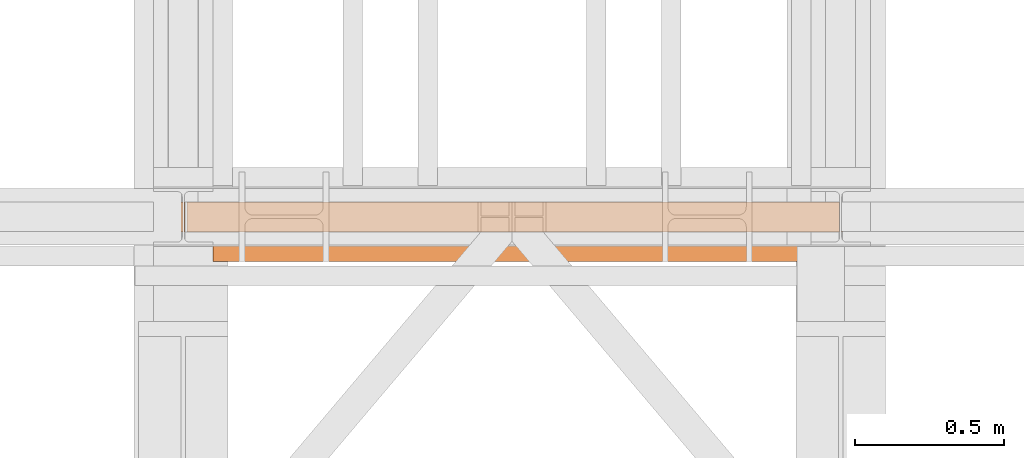
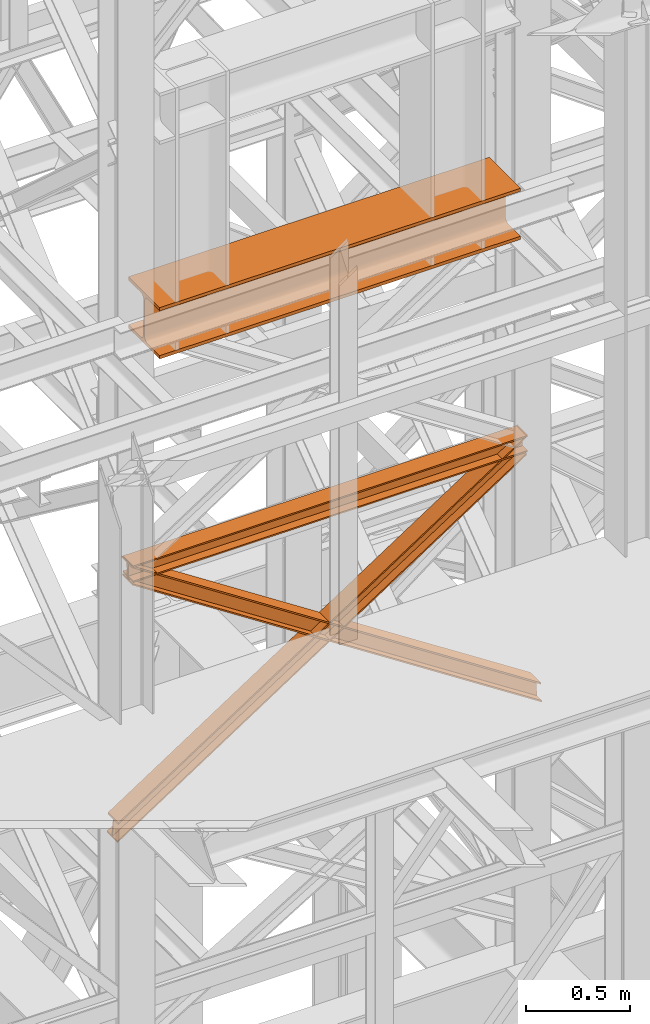
# One storey, part 147 of 208: 4 proxies.
"""IFC2X3 building model written with IfcOpenShell, lengths in millimetres."""

from ifc_helpers import new_model, entity, si_unit, converted_unit, frame, origin, origin_with_axes, place, context, subcontext, project, spatial, faceted_brep, element, save


model = new_model("IFC2X3")

# Units and contexts
model_context = context("Model", 3, precision=1e-05, world=origin())
plan_context = context("Plan", 3, precision=1e-05, world=origin())
body_context = subcontext(model_context, "Body", "Model", "MODEL_VIEW")
ifc_project = project(units=[si_unit("LENGTHUNIT", "METRE", prefix="MILLI"), converted_unit("PLANEANGLEUNIT", "DEGREE", entity("IfcPlaneAngleMeasure", 0.0174532925199433), si_unit("PLANEANGLEUNIT", "RADIAN"), dimensions=[0, 0, 0, 0, 0, 0, 0]), si_unit("AREAUNIT", "SQUARE_METRE"), si_unit("VOLUMEUNIT", "CUBIC_METRE")], contexts=[model_context, plan_context])

# Building, storey
building_placement = place(None, origin())
building = spatial("IfcBuilding", under=ifc_project, at=building_placement, CompositionType="COMPLEX")
storey_placement = place(building_placement, origin_with_axes())
storey = spatial("IfcBuildingStorey", under=building, at=storey_placement, Name="Geschoss", CompositionType="ELEMENT")

# Proxies
proxy_1_placement = place(storey_placement, frame((3393.254970018782, -16112.48734116498, 9568.990058693806), z_axis=(0.0, 0.0, 1.0), x_axis=(1.0, 0.0, 0.0)))
element("IfcBuildingElementProxy", 1, at=proxy_1_placement, inside=storey, context=body_context, shape_type="Brep", body=[
    faceted_brep([(0.01000000000021828, 300.0100000000002, 0.01000000000021828), (2000.009997019768, 300.0100000000002, 0.01000000000021828), (2000.009997019768, 300.0100000000002, 19.01000000000022), (0.01000000000021828, 300.0100000000002, 19.01000000000022), (0.01000000000021828, 300.0100000000002, 19.01000000000022), (2000.009997019768, 300.0100000000002, 19.01000000000022), (2000.009997019768, 182.5100000000002, 19.01000000000022), (0.01000000000021828, 182.5100000000002, 19.01000000000022), (0.01000000000021828, 182.5100000000002, 19.01000000000022), (2000.009997019768, 182.5100000000002, 19.01000000000022), (2000.009997019768, 175.5219092192219, 19.93008181249388), (0.01000000000021828, 175.5219092192219, 19.93008181249388), (0.01000000000021828, 175.5219092192219, 19.93008181249388), (2000.009997019768, 175.5219092192219, 19.93008181249388), (2000.009997019768, 169.0100393754565, 22.62738661818912), (0.01000000000021828, 169.0100393754565, 22.62738661818912), (0.01000000000021828, 169.0100393754565, 22.62738661818912), (2000.009997019768, 169.0100393754565, 22.62738661818912), (2000.009997019768, 163.4181169079584, 26.91811690796385), (0.01000000000021828, 163.4181169079584, 26.91811690796203), (0.01000000000021828, 163.4181169079584, 26.91811690796203), (2000.009997019768, 163.4181169079584, 26.91811690796385), (2000.009997019768, 159.1273866181855, 32.51003937545829), (0.01000000000021828, 159.1273866181855, 32.51003937545829), (0.01000000000021828, 159.1273866181855, 32.51003937545829), (2000.009997019768, 159.1273866181855, 32.51003937545829), (2000.009997019768, 156.4300818124921, 39.02190921922374), (0.01000000000021828, 156.4300818124921, 39.02190921922374), (0.01000000000021828, 156.4300818124921, 39.02190921922374), (2000.009997019768, 156.4300818124921, 39.02190921922374), (2000.009997019768, 155.5100000000002, 46.01000000000022), (0.01000000000021828, 155.5100000000002, 46.01000000000022), (0.01000000000021828, 155.5100000000002, 46.01000000000022), (2000.009997019768, 155.5100000000002, 46.01000000000022), (2000.009997019768, 155.5100000000002, 254.0100000000002), (0.01000000000021828, 155.5100000000002, 254.0100000000002), (0.01000000000021828, 155.5100000000002, 254.0100000000002), (2000.009997019768, 155.5100000000002, 254.0100000000002), (2000.009997019768, 156.8315660577409, 262.3534305458597), (0.01000000000021828, 156.8315660577409, 262.3534305458597), (0.01000000000021828, 156.8315660577409, 262.3534305458597), (2000.009997019768, 156.8315660577409, 262.3534305458597), (2000.009997019768, 160.6665745365954, 269.8801750658022), (0.01000000000021828, 160.6665745365954, 269.8801750658004), (0.01000000000021828, 160.6665745365954, 269.8801750658004), (2000.009997019768, 160.6665745365954, 269.8801750658022), (2000.009997019768, 166.6398249341964, 275.8534254634014), (0.01000000000021828, 166.6398249341964, 275.8534254634014), (0.01000000000021828, 166.6398249341964, 275.8534254634014), (2000.009997019768, 166.6398249341964, 275.8534254634014), (2000.009997019768, 174.1665694541352, 279.6884339422595), (0.01000000000021828, 174.1665694541352, 279.6884339422595), (0.01000000000021828, 174.1665694541352, 279.6884339422595), (2000.009997019768, 174.1665694541352, 279.6884339422595), (2000.009997019768, 182.5100000000002, 281.0100000000002), (0.01000000000021828, 182.5100000000002, 281.0100000000002), (0.01000000000021828, 182.5100000000002, 281.0100000000002), (2000.009997019768, 182.5100000000002, 281.0100000000002), (2000.009997019768, 300.0100000000002, 281.0100000000002), (0.01000000000021828, 300.0100000000002, 281.0100000000002), (0.01000000000021828, 300.0100000000002, 281.0100000000002), (2000.009997019768, 300.0100000000002, 281.0100000000002), (2000.009997019768, 300.0100000000002, 300.0100000000002), (0.01000000000021828, 300.0100000000002, 300.0100000000002), (0.01000000000021828, 300.0100000000002, 300.0100000000002), (2000.009997019768, 300.0100000000002, 300.0100000000002), (2000.009997019768, 0.01000000000021828, 300.0100000000002), (0.01000000000021828, 0.01000000000021828, 300.0100000000002), (0.01000000000021828, 0.01000000000021828, 300.0100000000002), (2000.009997019768, 0.01000000000021828, 300.0100000000002), (2000.009997019768, 0.01000000000021828, 281.0100000000002), (0.01000000000021828, 0.01000000000021828, 281.0100000000002), (0.01000000000021828, 0.01000000000021828, 281.0100000000002), (2000.009997019768, 0.01000000000021828, 281.0100000000002), (2000.009997019768, 117.5100000000002, 281.0100000000002), (0.01000000000021828, 117.5100000000002, 281.0100000000002), (0.01000000000021828, 117.5100000000002, 281.0100000000002), (2000.009997019768, 117.5100000000002, 281.0100000000002), (2000.009997019768, 125.8534305458579, 279.6884339422595), (0.01000000000021828, 125.8534305458579, 279.6884339422595), (0.01000000000021828, 125.8534305458579, 279.6884339422595), (2000.009997019768, 125.8534305458579, 279.6884339422595), (2000.009997019768, 133.3801750658004, 275.8534254634014), (0.01000000000021828, 133.3801750658004, 275.8534254634014), (0.01000000000021828, 133.3801750658004, 275.8534254634014), (2000.009997019768, 133.3801750658004, 275.8534254634014), (2000.009997019768, 139.3534254633978, 269.8801750658022), (0.01000000000021828, 139.3534254633978, 269.8801750658004), (0.01000000000021828, 139.3534254633978, 269.8801750658004), (2000.009997019768, 139.3534254633978, 269.8801750658022), (2000.009997019768, 143.1884339422595, 262.3534305458616), (0.01000000000021828, 143.1884339422595, 262.3534305458616), (0.01000000000021828, 143.1884339422595, 262.3534305458616), (2000.009997019768, 143.1884339422595, 262.3534305458616), (2000.009997019768, 144.5100000000002, 254.0100000000002), (0.01000000000021828, 144.5100000000002, 254.0100000000002), (0.01000000000021828, 144.5100000000002, 254.0100000000002), (2000.009997019768, 144.5100000000002, 254.0100000000002), (2000.009997019768, 144.5100000000002, 46.01000000000022), (0.01000000000021828, 144.5100000000002, 46.01000000000022), (0.01000000000021828, 144.5100000000002, 46.01000000000022), (2000.009997019768, 144.5100000000002, 46.01000000000022), (2000.009997019768, 143.1884339422595, 37.66656945413888), (0.01000000000021828, 143.1884339422595, 37.66656945413888), (0.01000000000021828, 143.1884339422595, 37.66656945413888), (2000.009997019768, 143.1884339422595, 37.66656945413888), (2000.009997019768, 139.3534254633978, 30.13982493419826), (0.01000000000021828, 139.3534254633978, 30.13982493419826), (0.01000000000021828, 139.3534254633978, 30.13982493419826), (2000.009997019768, 139.3534254633978, 30.13982493419826), (2000.009997019768, 133.3801750658004, 24.16657453659718), (0.01000000000021828, 133.3801750658004, 24.16657453659718), (0.01000000000021828, 133.3801750658004, 24.16657453659718), (2000.009997019768, 133.3801750658004, 24.16657453659718), (2000.009997019768, 125.8534305458579, 20.33156605774093), (0.01000000000021828, 125.8534305458579, 20.33156605774093), (0.01000000000021828, 125.8534305458579, 20.33156605774093), (2000.009997019768, 125.8534305458579, 20.33156605774093), (2000.009997019768, 117.5100000000002, 19.01000000000022), (0.01000000000021828, 117.5100000000002, 19.01000000000022), (0.01000000000021828, 117.5100000000002, 19.01000000000022), (2000.009997019768, 117.5100000000002, 19.01000000000022), (2000.009997019768, 0.01000000000021828, 19.01000000000022), (0.01000000000021828, 0.01000000000021828, 19.01000000000022), (0.01000000000021828, 0.01000000000021828, 19.01000000000022), (2000.009997019768, 0.01000000000021828, 19.01000000000022), (2000.009997019768, 0.01000000000021828, 0.01000000000021828), (0.01000000000021828, 0.01000000000021828, 0.01000000000021828), (0.01000000000021828, 0.01000000000021828, 0.01000000000021828), (2000.009997019768, 0.01000000000021828, 0.01000000000021828), (2000.009997019768, 300.0100000000002, 0.01000000000021828), (0.01000000000021828, 300.0100000000002, 0.01000000000021828), (0.01000000000021828, 300.0100000000002, 0.01000000000021828), (0.01000000000021828, 300.0100000000002, 19.01000000000022), (0.01000000000021828, 182.5100000000002, 19.01000000000022), (0.01000000000021828, 175.5219092192219, 19.93008181249388), (0.01000000000021828, 169.0100393754565, 22.62738661818912), (0.01000000000021828, 163.4181169079584, 26.91811690796203), (0.01000000000021828, 159.1273866181855, 32.51003937545829), (0.01000000000021828, 156.4300818124921, 39.02190921922374), (0.01000000000021828, 155.5100000000002, 46.01000000000022), (0.01000000000021828, 155.5100000000002, 254.0100000000002), (0.01000000000021828, 156.8315660577409, 262.3534305458597), (0.01000000000021828, 160.6665745365954, 269.8801750658004), (0.01000000000021828, 166.6398249341964, 275.8534254634014), (0.01000000000021828, 174.1665694541352, 279.6884339422595), (0.01000000000021828, 182.5100000000002, 281.0100000000002), (0.01000000000021828, 300.0100000000002, 281.0100000000002), (0.01000000000021828, 300.0100000000002, 300.0100000000002), (0.01000000000021828, 0.01000000000021828, 300.0100000000002), (0.01000000000021828, 0.01000000000021828, 281.0100000000002), (0.01000000000021828, 117.5100000000002, 281.0100000000002), (0.01000000000021828, 125.8534305458579, 279.6884339422595), (0.01000000000021828, 133.3801750658004, 275.8534254634014), (0.01000000000021828, 139.3534254633978, 269.8801750658004), (0.01000000000021828, 143.1884339422595, 262.3534305458616), (0.01000000000021828, 144.5100000000002, 254.0100000000002), (0.01000000000021828, 144.5100000000002, 46.01000000000022), (0.01000000000021828, 143.1884339422595, 37.66656945413888), (0.01000000000021828, 139.3534254633978, 30.13982493419826), (0.01000000000021828, 133.3801750658004, 24.16657453659718), (0.01000000000021828, 125.8534305458579, 20.33156605774093), (0.01000000000021828, 117.5100000000002, 19.01000000000022), (0.01000000000021828, 0.01000000000021828, 19.01000000000022), (0.01000000000021828, 0.01000000000021828, 0.01000000000021828), (2000.009997019768, 300.0100000000002, 0.01000000000021828), (2000.009997019768, 0.01000000000021828, 0.01000000000021828), (2000.009997019768, 0.01000000000021828, 19.01000000000022), (2000.009997019768, 117.5100000000002, 19.01000000000022), (2000.009997019768, 125.8534305458579, 20.33156605774093), (2000.009997019768, 133.3801750658004, 24.16657453659718), (2000.009997019768, 139.3534254633978, 30.13982493419826), (2000.009997019768, 143.1884339422595, 37.66656945413888), (2000.009997019768, 144.5100000000002, 46.01000000000022), (2000.009997019768, 144.5100000000002, 254.0100000000002), (2000.009997019768, 143.1884339422595, 262.3534305458616), (2000.009997019768, 139.3534254633978, 269.8801750658022), (2000.009997019768, 133.3801750658004, 275.8534254634014), (2000.009997019768, 125.8534305458579, 279.6884339422595), (2000.009997019768, 117.5100000000002, 281.0100000000002), (2000.009997019768, 0.01000000000021828, 281.0100000000002), (2000.009997019768, 0.01000000000021828, 300.0100000000002), (2000.009997019768, 300.0100000000002, 300.0100000000002), (2000.009997019768, 300.0100000000002, 281.0100000000002), (2000.009997019768, 182.5100000000002, 281.0100000000002), (2000.009997019768, 174.1665694541352, 279.6884339422595), (2000.009997019768, 166.6398249341964, 275.8534254634014), (2000.009997019768, 160.6665745365954, 269.8801750658022), (2000.009997019768, 156.8315660577409, 262.3534305458597), (2000.009997019768, 155.5100000000002, 254.0100000000002), (2000.009997019768, 155.5100000000002, 46.01000000000022), (2000.009997019768, 156.4300818124921, 39.02190921922374), (2000.009997019768, 159.1273866181855, 32.51003937545829), (2000.009997019768, 163.4181169079584, 26.91811690796385), (2000.009997019768, 169.0100393754565, 22.62738661818912), (2000.009997019768, 175.5219092192219, 19.93008181249388), (2000.009997019768, 182.5100000000002, 19.01000000000022), (2000.009997019768, 300.0100000000002, 19.01000000000022)], [[[0, 1, 2, 3]], [[4, 5, 6, 7]], [[8, 9, 10, 11]], [[12, 13, 14, 15]], [[16, 17, 18, 19]], [[20, 21, 22, 23]], [[24, 25, 26, 27]], [[28, 29, 30, 31]], [[32, 33, 34, 35]], [[36, 37, 38, 39]], [[40, 41, 42, 43]], [[44, 45, 46, 47]], [[48, 49, 50, 51]], [[52, 53, 54, 55]], [[56, 57, 58, 59]], [[60, 61, 62, 63]], [[64, 65, 66, 67]], [[68, 69, 70, 71]], [[72, 73, 74, 75]], [[76, 77, 78, 79]], [[80, 81, 82, 83]], [[84, 85, 86, 87]], [[88, 89, 90, 91]], [[92, 93, 94, 95]], [[96, 97, 98, 99]], [[100, 101, 102, 103]], [[104, 105, 106, 107]], [[108, 109, 110, 111]], [[112, 113, 114, 115]], [[116, 117, 118, 119]], [[120, 121, 122, 123]], [[124, 125, 126, 127]], [[128, 129, 130, 131]], [[132, 133, 134, 135, 136, 137, 138, 139, 140, 141, 142, 143, 144, 145, 146, 147, 148, 149, 150, 151, 152, 153, 154, 155, 156, 157, 158, 159, 160, 161, 162, 163, 164]], [[165, 166, 167, 168, 169, 170, 171, 172, 173, 174, 175, 176, 177, 178, 179, 180, 181, 182, 183, 184, 185, 186, 187, 188, 189, 190, 191, 192, 193, 194, 195, 196, 197]]], orient=[[False], [False], [False], [False], [False], [False], [False], [False], [False], [False], [False], [False], [False], [False], [False], [False], [False], [False], [False], [False], [False], [False], [False], [False], [False], [False], [False], [False], [False], [False], [False], [False], [False], [False], [False]]),
])
proxy_2_placement = place(storey_placement, frame((3305.189158585883, -16012.57439031789, 8230.356417081652), z_axis=(0.0, 0.0, 1.0), x_axis=(1.0, 0.0, 0.0)))
element("IfcBuildingElementProxy", 2, at=proxy_2_placement, inside=storey, context=body_context, shape_type="Brep", body=[
    faceted_brep([(2184.825809875727, 0.01000000000021828, 8.010000000000218), (2184.825809875727, 47.51000000000022, 8.010000000000218), (2184.825809875727, 47.51000000000022, 88.01000000000204), (2184.825809875727, 0.01000000000021828, 88.01000000000204), (2184.825809875727, 0.01000000000021828, 96.01000000000022), (2184.825809875727, 100.0100000000002, 96.01000000000022), (2184.825809875727, 100.0100000000002, 88.01000000000204), (2184.825809875727, 52.51000000000022, 88.01000000000204), (2184.825809875727, 52.51000000000022, 8.010000000000218), (2184.825809875727, 100.0100000000002, 8.010000000000218), (2184.825809875727, 100.0100000000002, 0.01000000000021828), (2184.825809875727, 0.01000000000021828, 0.01000000000021828), (2184.825809875727, 0.01000000000021828, 0.01000000000021828), (0.01000000000021828, 0.01000000000385626, 0.01000000000203727), (0.01000000000021828, 0.01000000000385626, 8.010000000000218), (2184.825809875727, 0.01000000000021828, 8.010000000000218), (2184.825809875727, 100.0100000000002, 0.01000000000021828), (0.01000000000021828, 100.0100000000039, 0.01000000000021828), (0.01000000000021828, 0.01000000000385626, 0.01000000000203727), (2184.825809875727, 0.01000000000021828, 0.01000000000021828), (2184.825809875727, 100.0100000000002, 8.010000000000218), (0.01000000000021828, 100.0100000000039, 8.010000000000218), (0.01000000000021828, 100.0100000000039, 0.01000000000021828), (2184.825809875727, 100.0100000000002, 0.01000000000021828), (2184.825809875727, 52.51000000000022, 8.010000000000218), (0.01000000000021828, 52.51000000000386, 8.010000000000218), (0.01000000000021828, 100.0100000000039, 8.010000000000218), (2184.825809875727, 100.0100000000002, 8.010000000000218), (2184.825809875727, 52.51000000000022, 88.01000000000204), (0.01000000000021828, 52.51000000000386, 88.01000000000204), (0.01000000000021828, 52.51000000000386, 8.010000000000218), (2184.825809875727, 52.51000000000022, 8.010000000000218), (2184.825809875727, 100.0100000000002, 88.01000000000204), (0.01000000000021828, 100.0100000000039, 88.01000000000204), (0.01000000000021828, 52.51000000000386, 88.01000000000204), (2184.825809875727, 52.51000000000022, 88.01000000000204), (2184.825809875727, 100.0100000000002, 96.01000000000022), (0.01000000000021828, 100.0100000000039, 96.01000000000022), (0.01000000000021828, 100.0100000000039, 88.01000000000204), (2184.825809875727, 100.0100000000002, 88.01000000000204), (2184.825809875727, 0.01000000000021828, 96.01000000000022), (0.01000000000021828, 0.01000000000385626, 96.01000000000022), (0.01000000000021828, 100.0100000000039, 96.01000000000022), (2184.825809875727, 100.0100000000002, 96.01000000000022), (2184.825809875727, 0.01000000000021828, 88.01000000000204), (0.01000000000021828, 0.01000000000385626, 88.01000000000022), (0.01000000000021828, 0.01000000000385626, 96.01000000000022), (2184.825809875727, 0.01000000000021828, 96.01000000000022), (2184.825809875727, 47.51000000000022, 88.01000000000204), (0.01000000000021828, 47.51000000000386, 88.01000000000204), (0.01000000000021828, 0.01000000000385626, 88.01000000000022), (2184.825809875727, 0.01000000000021828, 88.01000000000204), (2184.825809875727, 47.51000000000022, 8.010000000000218), (0.01000000000021828, 47.51000000000386, 8.010000000000218), (0.01000000000021828, 47.51000000000386, 88.01000000000204), (2184.825809875727, 47.51000000000022, 88.01000000000204), (2184.825809875727, 0.01000000000021828, 8.010000000000218), (0.01000000000021828, 0.01000000000385626, 8.010000000000218), (0.01000000000021828, 47.51000000000386, 8.010000000000218), (2184.825809875727, 47.51000000000022, 8.010000000000218), (0.01000000000021828, 0.01000000000385626, 8.010000000000218), (0.01000000000021828, 0.01000000000385626, 0.01000000000203727), (0.01000000000021828, 100.0100000000039, 0.01000000000021828), (0.01000000000021828, 100.0100000000039, 8.010000000000218), (0.01000000000021828, 52.51000000000386, 8.010000000000218), (0.01000000000021828, 52.51000000000386, 88.01000000000204), (0.01000000000021828, 100.0100000000039, 88.01000000000204), (0.01000000000021828, 100.0100000000039, 96.01000000000022), (0.01000000000021828, 0.01000000000385626, 96.01000000000022), (0.01000000000021828, 0.01000000000385626, 88.01000000000022), (0.01000000000021828, 47.51000000000386, 88.01000000000204), (0.01000000000021828, 47.51000000000386, 8.010000000000218)], [[[0, 1, 2, 3, 4, 5, 6, 7, 8, 9, 10, 11]], [[12, 13, 14, 15]], [[16, 17, 18, 19]], [[20, 21, 22, 23]], [[24, 25, 26, 27]], [[28, 29, 30, 31]], [[32, 33, 34, 35]], [[36, 37, 38, 39]], [[40, 41, 42, 43]], [[44, 45, 46, 47]], [[48, 49, 50, 51]], [[52, 53, 54, 55]], [[56, 57, 58, 59]], [[60, 61, 62, 63, 64, 65, 66, 67, 68, 69, 70, 71]]], orient=[[False], [False], [False], [False], [False], [False], [False], [False], [False], [False], [False], [False], [False], [False]]),
])
proxy_3_placement = place(storey_placement, frame((3217.091035327221, -16012.57439031789, 6735.828069372021), z_axis=(0.0, 0.0, 1.0), x_axis=(1.0, 0.0, 0.0)))
element("IfcBuildingElementProxy", 3, at=proxy_3_placement, inside=storey, context=body_context, shape_type="Brep", body=[
    faceted_brep([(2266.828242323492, 0.01000000000021828, 1478.089754817493), (0.01000000000021828, 0.01000000000203727, 0.01000000000021828), (0.4687052437129751, 0.01000000000203727, 9.68169352363384), (2267.286947567205, 0.01000000000021828, 1487.761448341124), (2266.828242323492, 100.0100000000002, 1478.089754817491), (0.01000000000021828, 100.010000000002, 0.009999999999308784), (0.01000000000021828, 0.01000000000203727, 0.01000000000021828), (2266.828242323492, 0.01000000000021828, 1478.089754817493), (2267.286947567205, 100.0100000000002, 1487.761448341124), (0.4687052437129751, 100.010000000002, 9.68169352363384), (0.01000000000021828, 100.010000000002, 0.009999999999308784), (2266.828242323492, 100.0100000000002, 1478.089754817491), (2267.286947567205, 52.51000000000022, 1487.761448341124), (0.4687052437129751, 52.51000000000204, 9.68169352363384), (0.4687052437129751, 100.010000000002, 9.68169352363384), (2267.286947567205, 100.0100000000002, 1487.761448341124), (2271.874000004329, 52.51000000000022, 1584.478383577458), (5.055757680838724, 52.51000000000022, 106.3986287599673), (0.4687052437129751, 52.51000000000204, 9.68169352363384), (2267.286947567205, 52.51000000000022, 1487.761448341124), (2271.874000004331, 100.0100000000002, 1584.478383577456), (5.055757680840543, 100.0100000000002, 106.3986287599673), (5.055757680838724, 52.51000000000022, 106.3986287599673), (2271.874000004329, 52.51000000000022, 1584.478383577458), (2272.332705248044, 100.0100000000002, 1594.150077101092), (5.514462924551481, 100.0100000000002, 116.0703222836009), (5.055757680840543, 100.0100000000002, 106.3986287599673), (2271.874000004331, 100.0100000000002, 1584.478383577456), (2272.332705248042, 0.01000000000021828, 1594.150077101092), (5.514462924551481, 0.01000000000021828, 116.0703222836009), (5.514462924551481, 100.0100000000002, 116.0703222836009), (2272.332705248044, 100.0100000000002, 1594.150077101092), (2271.874000004331, 0.01000000000021828, 1584.478383577456), (5.055757680838724, 0.01000000000021828, 106.3986287599664), (5.514462924551481, 0.01000000000021828, 116.0703222836009), (2272.332705248042, 0.01000000000021828, 1594.150077101092), (2271.874000004331, 47.51000000000022, 1584.478383577456), (5.055757680838724, 47.51000000000022, 106.3986287599664), (5.055757680838724, 0.01000000000021828, 106.3986287599664), (2271.874000004331, 0.01000000000021828, 1584.478383577456), (2267.286947567205, 47.51000000000022, 1487.761448341124), (0.4687052437129751, 47.51000000000204, 9.68169352363384), (5.055757680838724, 47.51000000000022, 106.3986287599664), (2271.874000004331, 47.51000000000022, 1584.478383577456), (2267.286947567205, 0.01000000000021828, 1487.761448341124), (0.4687052437129751, 0.01000000000203727, 9.68169352363384), (0.4687052437129751, 47.51000000000204, 9.68169352363384), (2267.286947567205, 47.51000000000022, 1487.761448341124), (2267.286947567205, 0.01000000000021828, 1487.761448341124), (2267.286947567205, 47.51000000000022, 1487.761448341124), (2271.874000004331, 47.51000000000022, 1584.478383577456), (2271.874000004331, 0.01000000000021828, 1584.478383577456), (2272.332705248042, 0.01000000000021828, 1594.150077101092), (2272.332705248044, 100.0100000000002, 1594.150077101092), (2271.874000004331, 100.0100000000002, 1584.478383577456), (2271.874000004329, 52.51000000000022, 1584.478383577458), (2267.286947567205, 52.51000000000022, 1487.761448341124), (2267.286947567205, 100.0100000000002, 1487.761448341124), (2266.828242323492, 100.0100000000002, 1478.089754817491), (2266.828242323492, 0.01000000000021828, 1478.089754817493), (0.01000000000021828, 0.01000000000203727, 0.01000000000021828), (0.01000000000021828, 100.010000000002, 0.009999999999308784), (0.4687052437129751, 100.010000000002, 9.68169352363384), (0.4687052437129751, 52.51000000000204, 9.68169352363384), (5.055757680838724, 52.51000000000022, 106.3986287599673), (5.055757680840543, 100.0100000000002, 106.3986287599673), (5.514462924551481, 100.0100000000002, 116.0703222836009), (5.514462924551481, 0.01000000000021828, 116.0703222836009), (5.055757680838724, 0.01000000000021828, 106.3986287599664), (5.055757680838724, 47.51000000000022, 106.3986287599664), (0.4687052437129751, 47.51000000000204, 9.68169352363384), (0.4687052437129751, 0.01000000000203727, 9.68169352363384)], [[[0, 1, 2, 3]], [[4, 5, 6, 7]], [[8, 9, 10, 11]], [[12, 13, 14, 15]], [[16, 17, 18, 19]], [[20, 21, 22, 23]], [[24, 25, 26, 27]], [[28, 29, 30, 31]], [[32, 33, 34, 35]], [[36, 37, 38, 39]], [[40, 41, 42, 43]], [[44, 45, 46, 47]], [[48, 49, 50, 51, 52, 53, 54, 55, 56, 57, 58, 59]], [[60, 61, 62, 63, 64, 65, 66, 67, 68, 69, 70, 71]]], orient=[[False], [False], [False], [False], [False], [False], [False], [False], [False], [False], [False], [False], [False], [False]]),
])
proxy_4_placement = place(storey_placement, frame((3297.096196482069, -16012.57439031789, 6735.828069372017), z_axis=(0.0, 0.0, 1.0), x_axis=(1.0, 0.0, 0.0)))
element("IfcBuildingElementProxy", 4, at=proxy_4_placement, inside=storey, context=body_context, shape_type="Brep", body=[
    faceted_brep([(5.514462924551481, 0.01000000000021828, 1478.089754817496), (5.055757680838724, 0.01000000000021828, 1487.761448341129), (2271.874000004331, 0.01000000000021828, 9.68169352363293), (2272.332705248044, 0.01000000000021828, 0.01000000000021828), (5.514462924551481, 100.0100000000002, 1478.089754817496), (5.514462924551481, 0.01000000000021828, 1478.089754817496), (2272.332705248044, 0.01000000000021828, 0.01000000000021828), (2272.332705248044, 100.0100000000002, 0.01000000000021828), (5.055757680838724, 100.0100000000002, 1487.761448341129), (5.514462924551481, 100.0100000000002, 1478.089754817496), (2272.332705248044, 100.0100000000002, 0.01000000000021828), (2271.874000004331, 100.0100000000002, 9.68169352363293), (5.055757680838724, 52.51000000000022, 1487.761448341129), (5.055757680838724, 100.0100000000002, 1487.761448341129), (2271.874000004331, 100.0100000000002, 9.68169352363293), (2271.874000004331, 52.51000000000022, 9.68169352363293), (0.4687052437147941, 52.51000000000022, 1584.478383577456), (5.055757680838724, 52.51000000000022, 1487.761448341129), (2271.874000004331, 52.51000000000022, 9.68169352363293), (2267.286947567205, 52.51000000000022, 106.3986287599673), (0.4687052437129751, 100.0100000000002, 1584.478383577456), (0.4687052437147941, 52.51000000000022, 1584.478383577456), (2267.286947567205, 52.51000000000022, 106.3986287599673), (2267.286947567203, 100.0100000000002, 106.3986287599673), (0.01000000000021828, 100.0100000000002, 1594.150077101096), (0.4687052437129751, 100.0100000000002, 1584.478383577456), (2267.286947567203, 100.0100000000002, 106.3986287599673), (2266.828242323492, 100.0100000000002, 116.0703222836), (0.01000000000203727, 0.01000000000021828, 1594.150077101096), (0.01000000000021828, 100.0100000000002, 1594.150077101096), (2266.828242323492, 100.0100000000002, 116.0703222836), (2266.828242323492, 0.01000000000021828, 116.0703222836), (0.4687052437129751, 0.01000000000021828, 1584.478383577456), (0.01000000000203727, 0.01000000000021828, 1594.150077101096), (2266.828242323492, 0.01000000000021828, 116.0703222836), (2267.286947567205, 0.01000000000021828, 106.3986287599673), (0.4687052437129751, 47.51000000000022, 1584.478383577456), (0.4687052437129751, 0.01000000000021828, 1584.478383577456), (2267.286947567205, 0.01000000000021828, 106.3986287599673), (2267.286947567205, 47.51000000000022, 106.3986287599673), (5.055757680838724, 47.51000000000022, 1487.761448341129), (0.4687052437129751, 47.51000000000022, 1584.478383577456), (2267.286947567205, 47.51000000000022, 106.3986287599673), (2271.874000004331, 47.51000000000022, 9.68169352363293), (5.055757680838724, 0.01000000000021828, 1487.761448341129), (5.055757680838724, 47.51000000000022, 1487.761448341129), (2271.874000004331, 47.51000000000022, 9.68169352363293), (2271.874000004331, 0.01000000000021828, 9.68169352363293), (5.055757680838724, 0.01000000000021828, 1487.761448341129), (5.514462924551481, 0.01000000000021828, 1478.089754817496), (5.514462924551481, 100.0100000000002, 1478.089754817496), (5.055757680838724, 100.0100000000002, 1487.761448341129), (5.055757680838724, 52.51000000000022, 1487.761448341129), (0.4687052437147941, 52.51000000000022, 1584.478383577456), (0.4687052437129751, 100.0100000000002, 1584.478383577456), (0.01000000000021828, 100.0100000000002, 1594.150077101096), (0.01000000000203727, 0.01000000000021828, 1594.150077101096), (0.4687052437129751, 0.01000000000021828, 1584.478383577456), (0.4687052437129751, 47.51000000000022, 1584.478383577456), (5.055757680838724, 47.51000000000022, 1487.761448341129), (2272.332705248044, 0.01000000000021828, 0.01000000000021828), (2271.874000004331, 0.01000000000021828, 9.68169352363293), (2271.874000004331, 47.51000000000022, 9.68169352363293), (2267.286947567205, 47.51000000000022, 106.3986287599673), (2267.286947567205, 0.01000000000021828, 106.3986287599673), (2266.828242323492, 0.01000000000021828, 116.0703222836), (2266.828242323492, 100.0100000000002, 116.0703222836), (2267.286947567203, 100.0100000000002, 106.3986287599673), (2267.286947567205, 52.51000000000022, 106.3986287599673), (2271.874000004331, 52.51000000000022, 9.68169352363293), (2271.874000004331, 100.0100000000002, 9.68169352363293), (2272.332705248044, 100.0100000000002, 0.01000000000021828)], [[[0, 1, 2, 3]], [[4, 5, 6, 7]], [[8, 9, 10, 11]], [[12, 13, 14, 15]], [[16, 17, 18, 19]], [[20, 21, 22, 23]], [[24, 25, 26, 27]], [[28, 29, 30, 31]], [[32, 33, 34, 35]], [[36, 37, 38, 39]], [[40, 41, 42, 43]], [[44, 45, 46, 47]], [[48, 49, 50, 51, 52, 53, 54, 55, 56, 57, 58, 59]], [[60, 61, 62, 63, 64, 65, 66, 67, 68, 69, 70, 71]]], orient=[[False], [False], [False], [False], [False], [False], [False], [False], [False], [False], [False], [False], [False], [False]]),
])

save(model, "model.ifc")
